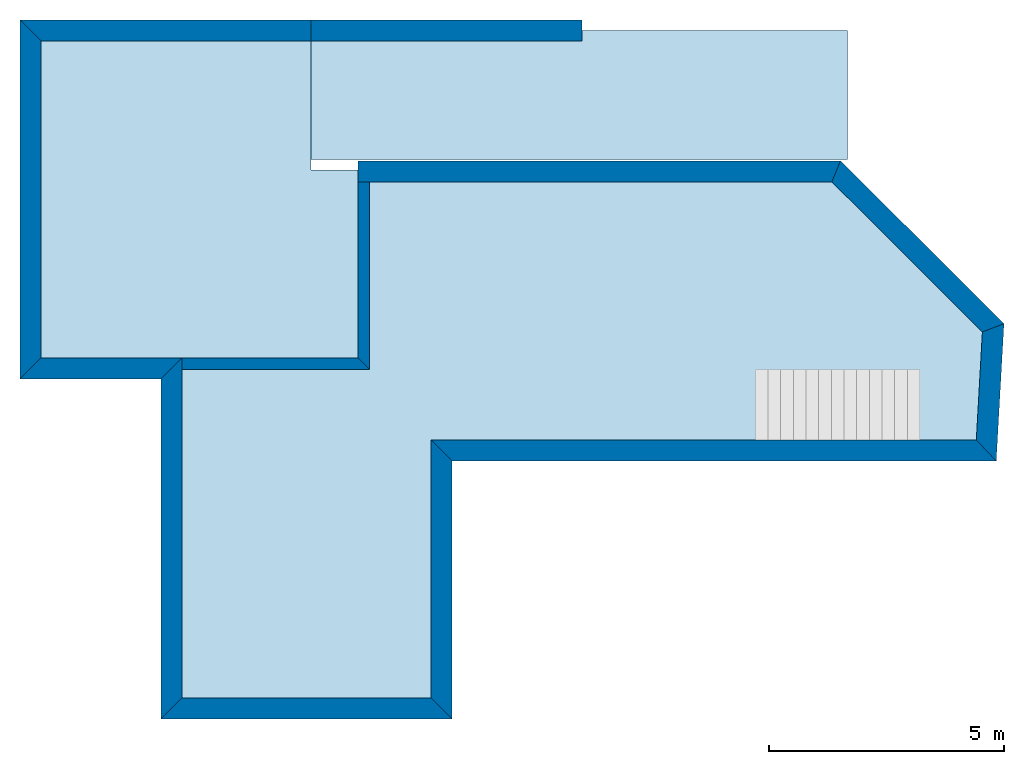
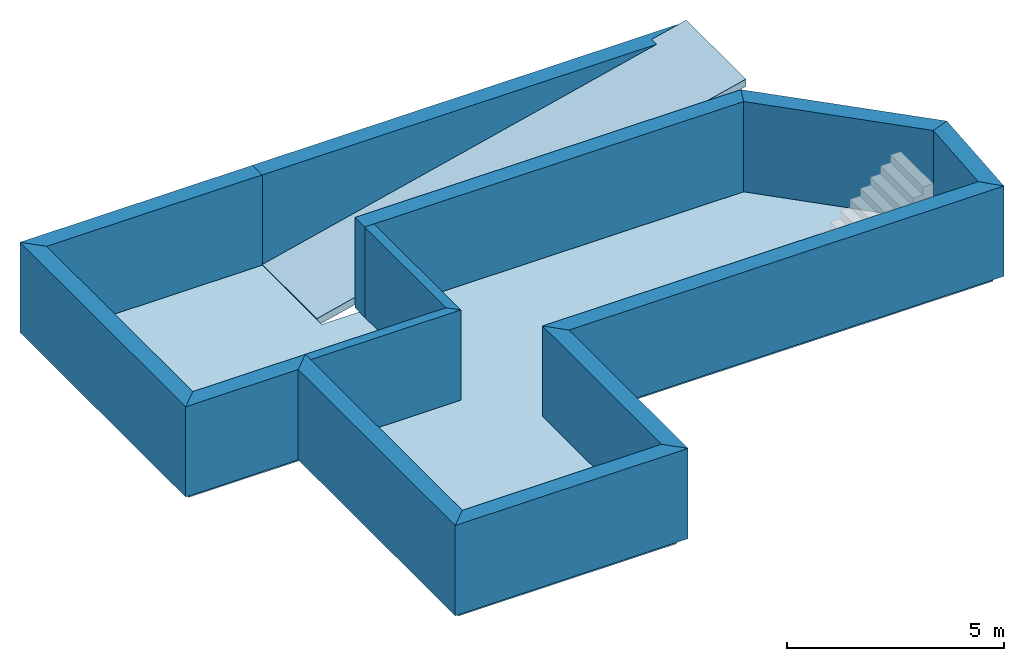
# One storey, part 1 of 2: 13 walls, 2 slabs.
"""IFC4 building model written with IfcOpenShell, lengths in millimetres."""

from ifc_helpers import new_model, entity, si_unit, converted_unit, frame, origin_with_axes, origin_2d_with_axis, place, context, subcontext, project, spatial, line, indexed_curve, outline, extrude, clip, halfspace, material, layer, layer_set, layer_usage, type_object, element, save


model = new_model("IFC4")

# Units and contexts
model_context = context("Model", 3, precision=1e-05, world=origin_with_axes())
plan_context = context("Plan", 2, precision=1e-05, world=origin_2d_with_axis())
body_context = subcontext(model_context, "Body", "Model", "MODEL_VIEW")
ifc_project = project(units=[si_unit("VOLUMEUNIT", "CUBIC_METRE"), si_unit("LENGTHUNIT", "METRE", prefix="MILLI"), converted_unit("PLANEANGLEUNIT", "degree", entity("IfcReal", 0.0174532925199433), si_unit("PLANEANGLEUNIT", "RADIAN"), dimensions=[0, 0, 0, 0, 0, 0, 0]), si_unit("AREAUNIT", "SQUARE_METRE")], contexts=[model_context, plan_context])

# Site, building, storey
site_placement = place(None, origin_with_axes())
site = spatial("IfcSite", under=ifc_project, at=site_placement)
building_placement = place(site_placement, origin_with_axes())
building = spatial("IfcBuilding", under=site, at=building_placement, Name="Building")
storey_placement = place(building_placement, frame((0.0, 0.0, -2799.99995231628), z_axis=(0.0, 0.0, 1.0), x_axis=(1.0, 0.0, 0.0)))
storey = spatial("IfcBuildingStorey", under=building, at=storey_placement, Name="KG")

# Slabs
ifc_material_1 = material(Name="Beton")
ifc_layer_1 = layer(ifc_material_1, 200.0, Name="Dach Beton", Priority=10)
ifc_layer_set_1 = layer_set([ifc_layer_1], Name="Dach")
ifc_layer_usage_1 = layer_usage(ifc_layer_set_1, "AXIS3", "POSITIVE", 0.0)
slab_type = type_object("IfcSlabType", Name="FB", PredefinedType="FLOOR", material=ifc_layer_set_1)
slab_1_placement = place(storey_placement, frame((0.0, 0.0, -250.000238418579), z_axis=(0.0, 0.0, 1.0), x_axis=(1.0, 0.0, 0.0)))
element("IfcSlab", 1, at=slab_1_placement, inside=storey, type_object=slab_type, material=ifc_layer_usage_1, Name="Slab", context=body_context, shape_type="SweptSolid", body=[
    extrude(outline(indexed_curve([(5811.1318359375, 5499.99609375), (11622.263671875, 5499.99609375), (17433.40625, 5499.99609375), (17568.12109375, 8138.05029296875), (14206.2001953125, 11499.990234375), (3000.0, 11499.990234375), (3000.0, 14499.9873046875), (-2999.99951171875, 14499.9873046875), (-2999.99951171875, 7249.99365234375), (0.000283117085928097, 7249.99365234375), (0.0, 0.0), (5811.1318359375, 0.0), (5811.1318359375, 5499.99609375)])), origin_with_axes(), (0.0, 0.0, 1.0), 200.0),
])
ifc_layer_usage_2 = layer_usage(ifc_layer_set_1, "AXIS3", "POSITIVE", -200.0)
slab_2_placement = place(storey_placement, frame((2769.9933052063, 14479.9423217773, -84.43284034729), z_axis=(-0.233445434365919, -1.76246411965181e-08, 0.972369903469717), x_axis=(7.54979012640431e-08, -0.999999999999997, 0.0)))
element("IfcSlab", 2, at=slab_2_placement, inside=storey, type_object=slab_type, material=ifc_layer_usage_2, Name="Slab", context=body_context, shape_type="SweptSolid", body=[
    extrude(outline(indexed_curve([(0.0, 236.542856185067), (2749.94213867188, 236.543421921606), (2749.943359375, 11999.7013216824), (-0.00196899846196175, 11999.6944716832), (0.0, 236.542856185067)])), frame((0.0, -48.015754699707, -200.0), z_axis=(0.0, 0.0, 1.0), x_axis=(1.0, 0.0, 0.0)), (0.0, 0.233445376157761, 0.972369909286499), 205.683041264277),
])

# Walls
ifc_layer_2 = layer(ifc_material_1, 250.0, Name="Beton Keller")
ifc_material_2 = material(Name="XPS")
ifc_layer_3 = layer(ifc_material_2, 200.0)
ifc_layer_set_2 = layer_set([ifc_layer_2, ifc_layer_3], Name="Wand")
ifc_layer_usage_3 = layer_usage(ifc_layer_set_2, "AXIS2", "NEGATIVE", 0.0)
wall_type_1 = type_object("IfcWallType", Name="Keller Wand 45cm", PredefinedType="SOLIDWALL", material=ifc_layer_set_2)
wall_1_placement = place(storey_placement, frame((14102.8935603036, 11249.9904411071, -50.0001907348633), z_axis=(0.0, 0.0, 1.0), x_axis=(-0.999999999999989, 1.50995802528085e-07, 0.0)))
element("IfcWall", 3, at=wall_1_placement, inside=storey, type_object=wall_type_1, material=ifc_layer_usage_3, Name="Wall", context=body_context, shape_type="SweptSolid", body=[
    extrude(outline(indexed_curve([(-185.954712863864, -450.0), (0.0, 0.0), (10102.8924059693, 0.0), (10102.8924059693, -450.0)], segments=[line(1, 2, 3, 4, 1)])), origin_with_axes(), (0.0, 0.0, 1.0), 2544.29364204407),
])
ifc_layer_usage_4 = layer_usage(ifc_layer_set_2, "AXIS2", "NEGATIVE", 0.0)
wall_2_placement = place(storey_placement, frame((3000.00047683716, 14249.9895095825, -50.0001907348633), z_axis=(0.0, 0.0, 1.0), x_axis=(-0.999999999999989, 1.50995802528085e-07, 0.0)))
element("IfcWall", 4, at=wall_2_placement, inside=storey, type_object=wall_type_1, material=ifc_layer_usage_4, Name="Wall", context=body_context, shape_type="SweptSolid", body=[
    extrude(outline(indexed_curve([(0.0, -450.0), (0.0, 0.0), (5750.0001897422, 0.0), (6200.00034530857, -450.0)], segments=[line(1, 2, 3, 4, 1)])), origin_with_axes(), (0.0, 0.0, 1.0), 2544.29364204407),
])
ifc_layer_usage_5 = layer_usage(ifc_layer_set_2, "AXIS2", "NEGATIVE", 0.0)
wall_3_placement = place(storey_placement, frame((250.001620242135, 249.999985098839, -50.0001907348633), z_axis=(0.0, 0.0, 1.0), x_axis=(1.0, 0.0, 0.0)))
element("IfcWall", 5, at=wall_3_placement, inside=storey, type_object=wall_type_1, material=ifc_layer_usage_5, Name="Wall", context=body_context, shape_type="SweptSolid", body=[
    extrude(outline(indexed_curve([(-449.999912381776, -450.0), (0.0, 0.0), (5311.13033395098, 0.0), (5761.13019268859, -450.0)], segments=[line(1, 2, 3, 4, 1)])), origin_with_axes(), (0.0, 0.0, 1.0), 2544.29364204407),
])
ifc_layer_usage_6 = layer_usage(ifc_layer_set_2, "AXIS2", "NEGATIVE", 0.0)
wall_4_placement = place(storey_placement, frame((5561.13195419312, 249.999985098839, -50.0001907348633), z_axis=(0.0, 0.0, 1.0), x_axis=(3.13916473260163e-07, 0.999999999999951, 0.0)))
element("IfcWall", 6, at=wall_4_placement, inside=storey, type_object=wall_type_1, material=ifc_layer_usage_6, Name="Wall", context=body_context, shape_type="SweptSolid", body=[
    extrude(outline(indexed_curve([(-449.999858737609, -450.0), (0.0, 0.0), (5499.99620020417, 0.0), (5049.99634146656, -450.0)], segments=[line(1, 2, 3, 4, 1)])), origin_with_axes(), (0.0, 0.0, 1.0), 2544.29364204407),
])
ifc_layer_usage_7 = layer_usage(ifc_layer_set_2, "AXIS2", "NEGATIVE", 0.0)
wall_5_placement = place(storey_placement, frame((5561.13368073253, 5749.99618530273, -50.0001907348633), z_axis=(0.0, 0.0, 1.0), x_axis=(1.0, 0.0, 0.0)))
element("IfcWall", 7, at=wall_5_placement, inside=storey, type_object=wall_type_1, material=ifc_layer_usage_7, Name="Wall", context=body_context, shape_type="SweptSolid", body=[
    extrude(outline(indexed_curve([(449.999858737609, -450.0), (0.0, 0.0), (11621.2381761609, 0.0), (12046.5680000228, -450.0)], segments=[line(1, 2, 3, 4, 1)])), origin_with_axes(), (0.0, 0.0, 1.0), 2544.29364204407),
])
ifc_layer_usage_8 = layer_usage(ifc_layer_set_2, "AXIS2", "POSITIVE", 0.0)
wall_6_placement = place(storey_placement, frame((3000.00047683716, 14249.9895095825, -50.0001907348633), z_axis=(0.0, 0.0, 1.0), x_axis=(1.0, 0.0, 0.0)))
element("IfcWall", 8, at=wall_6_placement, inside=storey, type_object=wall_type_1, material=ifc_layer_usage_8, Name="Wall", context=body_context, shape_type="Clipping", body=[
    clip(extrude(outline(indexed_curve([(0.0, 0.0), (0.0, 450.0), (11438.110335278, 450.0), (11438.110335278, 0.0)], segments=[line(1, 2, 3, 4, 1)])), origin_with_axes(), (0.0, 0.0, 1.0), 2544.29364204407), halfspace(frame((10951.951171875, 249.999984741211, 2444.435546875), z_axis=(0.233445376157761, -6.99186628594362e-08, -0.972369909286499), x_axis=(0.972369909286499, -3.78654817723145e-07, 0.233445376157761)), False)),
])
ifc_layer_usage_9 = layer_usage(ifc_layer_set_2, "AXIS2", "POSITIVE", 0.0)
wall_7_placement = place(storey_placement, frame((250.000208616264, 7499.993763368, -50.0001907348633), z_axis=(0.0, 0.0, 1.0), x_axis=(-0.999999999999989, 1.50995802528085e-07, 0.0)))
element("IfcWall", 9, at=wall_7_placement, inside=storey, type_object=wall_type_1, material=ifc_layer_usage_9, Name="Wall", context=body_context, shape_type="SweptSolid", body=[
    extrude(outline(indexed_curve([(0.0, 0.0), (449.999844433683, 450.0), (3449.99845168222, 450.0), (2999.99860724854, 0.0)], segments=[line(1, 2, 3, 4, 1)])), origin_with_axes(), (0.0, 0.0, 1.0), 2544.29364204407),
])
ifc_layer_usage_10 = layer_usage(ifc_layer_set_2, "AXIS2", "NEGATIVE", 0.0)
wall_8_placement = place(storey_placement, frame((250.000208616264, 7499.993763368, -50.0001907348633), z_axis=(0.0, 0.0, 1.0), x_axis=(1.94707183709394e-07, -0.999999999999981, 0.0)))
element("IfcWall", 10, at=wall_8_placement, inside=storey, type_object=wall_type_1, material=ifc_layer_usage_10, Name="Wall", context=body_context, shape_type="SweptSolid", body=[
    extrude(outline(indexed_curve([(449.999844433683, -450.0), (0.0, 0.0), (7249.9937782693, 0.0), (7699.99369065108, -450.0)], segments=[line(1, 2, 3, 4, 1)])), origin_with_axes(), (0.0, 0.0, 1.0), 2544.29364204407),
])
ifc_layer_usage_11 = layer_usage(ifc_layer_set_2, "AXIS2", "NEGATIVE", 0.0)
wall_9_placement = place(storey_placement, frame((-2749.99971290498, 14249.9903778084, -50.0001907348633), z_axis=(0.0, 0.0, 1.0), x_axis=(1.94707183709394e-07, -0.999999999999981, 0.0)))
element("IfcWall", 11, at=wall_9_placement, inside=storey, type_object=wall_type_1, material=ifc_layer_usage_11, Name="Wall", context=body_context, shape_type="SweptSolid", body=[
    extrude(outline(indexed_curve([(-450.000155566371, -450.0), (0.0, 0.0), (6749.99616145334, 0.0), (7199.99600588702, -450.0)], segments=[line(1, 2, 3, 4, 1)])), origin_with_axes(), (0.0, 0.0, 1.0), 2544.29364204407),
])
ifc_layer_usage_12 = layer_usage(ifc_layer_set_2, "AXIS2", "NEGATIVE", 0.0)
wall_10_placement = place(storey_placement, frame((17182.3718568934, 5749.99618530273, -50.0001907348633), z_axis=(0.0, 0.0, 1.0), x_axis=(0.0563229876439106, 0.998412600613025, 0.0)))
element("IfcWall", 12, at=wall_10_placement, inside=storey, type_object=wall_type_1, material=ifc_layer_usage_12, Name="Wall", context=body_context, shape_type="SweptSolid", body=[
    extrude(outline(indexed_curve([(-425.329823861901, -450.0), (0.0, 0.0), (2305.07853710456, 0.0), (2506.96142857214, -450.0)], segments=[line(1, 2, 3, 4, 1)])), origin_with_axes(), (0.0, 0.0, 1.0), 2544.29364204407),
])
ifc_layer_usage_13 = layer_usage(ifc_layer_set_2, "AXIS2", "NEGATIVE", 0.0)
wall_11_placement = place(storey_placement, frame((17312.200766857, 8051.41564215056, -50.3494739532471), z_axis=(0.0, 0.0, 1.0), x_axis=(-0.708290103893008, 0.705921474901587, 0.0)))
element("IfcWall", 13, at=wall_11_placement, inside=storey, type_object=wall_type_1, material=ifc_layer_usage_13, Name="Wall", context=body_context, shape_type="SweptSolid", body=[
    extrude(outline(indexed_curve([(-201.882891467579, -450.0), (0.0, 0.0), (4531.06317441675, 0.0), (4717.01788728062, -450.0)], segments=[line(1, 2, 3, 4, 1)])), origin_with_axes(), (0.0, 0.0, 1.0), 2544.29364204407),
])
ifc_layer_4 = layer(ifc_material_1, 250.0)
ifc_layer_set_3 = layer_set([ifc_layer_4])
ifc_layer_usage_14 = layer_usage(ifc_layer_set_3, "AXIS2", "POSITIVE", 0.0)
wall_type_2 = type_object("IfcWallType", Name="Keller Wand innen 25cm", PredefinedType="SOLIDWALL", material=ifc_layer_set_3)
wall_12_placement = place(storey_placement, frame((4000.00095367432, 11249.9923706055, -50.0001907348633), z_axis=(0.0, 0.0, 1.0), x_axis=(-1.62920684942944e-07, -0.999999999999987, 0.0)))
element("IfcWall", 14, at=wall_12_placement, inside=storey, type_object=wall_type_2, material=ifc_layer_usage_14, Name="Wall", context=body_context, shape_type="SweptSolid", body=[
    extrude(outline(indexed_curve([(0.0, 0.0), (0.0, 250.0), (3999.92700318301, 250.0), (3749.93151422084, 0.0)], segments=[line(1, 2, 3, 4, 1)])), origin_with_axes(), (0.0, 0.0, 1.0), 2544.29364204407),
])
ifc_layer_usage_15 = layer_usage(ifc_layer_set_3, "AXIS2", "POSITIVE", 0.0)
wall_13_placement = place(storey_placement, frame((250.000208616257, 7249.99380111694, -50.0001907348633), z_axis=(0.0, 0.0, 1.0), x_axis=(0.999999999840128, 1.78813934297585e-05, 0.0)))
element("IfcWall", 15, at=wall_13_placement, inside=storey, type_object=wall_type_2, material=ifc_layer_usage_15, Name="Wall", context=body_context, shape_type="SweptSolid", body=[
    extrude(outline(indexed_curve([(0.0, 0.0), (0.0, 250.0), (3750.00460506453, 250.0), (4000.0000940267, 0.0)], segments=[line(1, 2, 3, 4, 1)])), origin_with_axes(), (0.0, 0.0, 1.0), 2544.29364204407),
])

save(model, "model.ifc")
